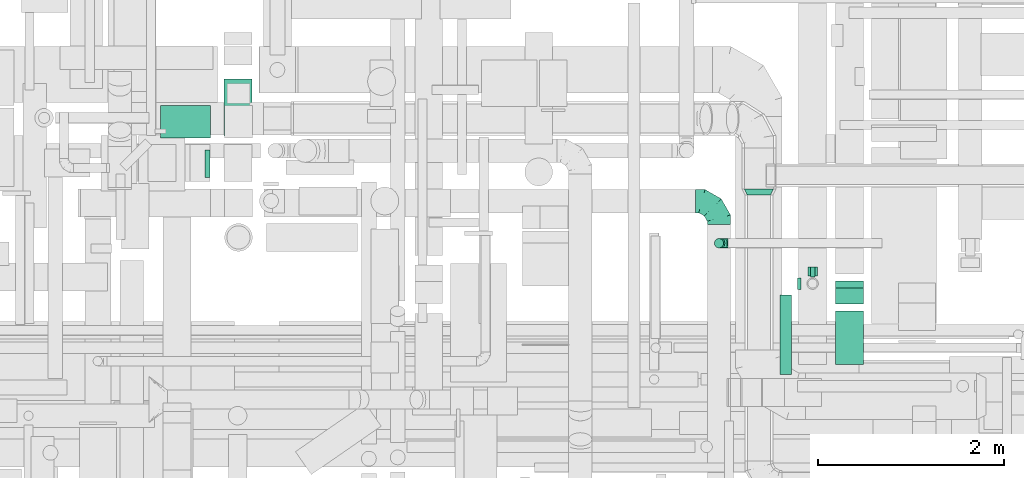
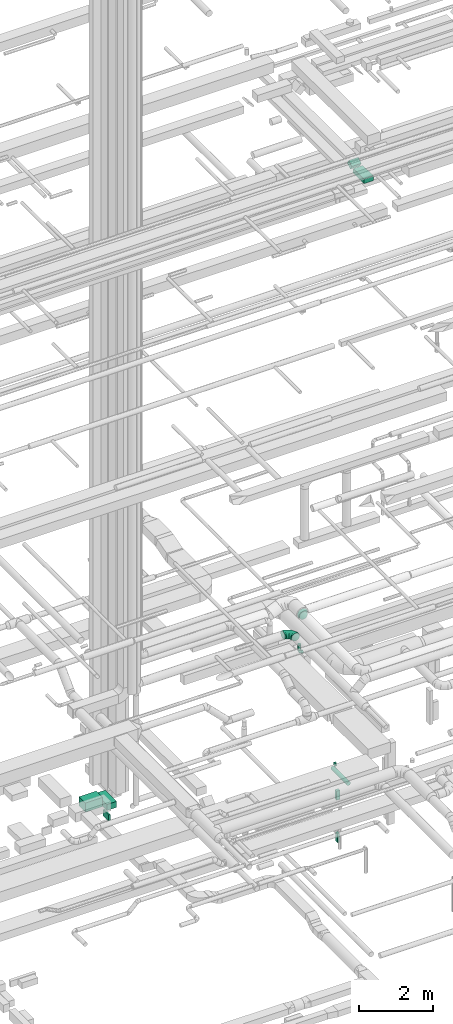
# One storey, part 144 of 337: 10 flow segments, 4 flow fittings.
"""IFC2X3 building model written with IfcOpenShell, lengths in millimetres."""

from ifc_helpers import new_model, entity, si_unit, converted_unit, derived_unit, direction, frame, frame_2d, origin, origin_2d_with_axis, place, context, subcontext, project, spatial, rectangle, circle, extrude, faceted_brep, source, transform, mapped, material, type_object, type_shapes, element, save


model = new_model("IFC2X3")

# Units and contexts
model_context = context("Model", 3, precision=0.01, world=origin(), true_north=direction((6.12303176911189e-17, 1.0)))
body_context = subcontext(model_context, "Body", "Model", "MODEL_VIEW")
ifc_project = project(units=[si_unit("LENGTHUNIT", "METRE", prefix="MILLI"), si_unit("AREAUNIT", "SQUARE_METRE"), si_unit("VOLUMEUNIT", "CUBIC_METRE"), converted_unit("PLANEANGLEUNIT", "DEGREE", entity("IfcRatioMeasure", 0.0174532925199433), si_unit("PLANEANGLEUNIT", "RADIAN"), dimensions=[0, 0, 0, 0, 0, 0, 0]), si_unit("MASSUNIT", "GRAM", prefix="KILO"), derived_unit("MASSDENSITYUNIT", [(si_unit("MASSUNIT", "GRAM", prefix="KILO"), 1), (si_unit("LENGTHUNIT", "METRE"), -3)]), derived_unit("MOMENTOFINERTIAUNIT", [(si_unit("LENGTHUNIT", "METRE"), 4)]), si_unit("TIMEUNIT", "SECOND"), si_unit("FREQUENCYUNIT", "HERTZ"), si_unit("THERMODYNAMICTEMPERATUREUNIT", "DEGREE_CELSIUS"), derived_unit("THERMALTRANSMITTANCEUNIT", [(si_unit("MASSUNIT", "GRAM", prefix="KILO"), 1), (si_unit("THERMODYNAMICTEMPERATUREUNIT", "KELVIN"), -1), (si_unit("TIMEUNIT", "SECOND"), -3)]), derived_unit("VOLUMETRICFLOWRATEUNIT", [(si_unit("LENGTHUNIT", "METRE"), 3), (si_unit("TIMEUNIT", "SECOND"), -1)]), derived_unit("MASSFLOWRATEUNIT", [(si_unit("MASSUNIT", "GRAM", prefix="KILO"), 1), (si_unit("TIMEUNIT", "SECOND"), -1)]), derived_unit("ROTATIONALFREQUENCYUNIT", [(si_unit("TIMEUNIT", "SECOND"), -1)]), si_unit("ELECTRICCURRENTUNIT", "AMPERE"), si_unit("ELECTRICVOLTAGEUNIT", "VOLT"), si_unit("POWERUNIT", "WATT"), si_unit("FORCEUNIT", "NEWTON", prefix="KILO"), si_unit("ILLUMINANCEUNIT", "LUX"), si_unit("LUMINOUSFLUXUNIT", "LUMEN"), si_unit("LUMINOUSINTENSITYUNIT", "CANDELA"), derived_unit("USERDEFINED", [(si_unit("MASSUNIT", "GRAM", prefix="KILO"), -1), (si_unit("LENGTHUNIT", "METRE"), -2), (si_unit("TIMEUNIT", "SECOND"), 3), (si_unit("LUMINOUSFLUXUNIT", "LUMEN"), 1)]), derived_unit("LINEARVELOCITYUNIT", [(si_unit("LENGTHUNIT", "METRE"), 1), (si_unit("TIMEUNIT", "SECOND"), -1)]), si_unit("PRESSUREUNIT", "PASCAL"), derived_unit("USERDEFINED", [(si_unit("LENGTHUNIT", "METRE"), -2), (si_unit("MASSUNIT", "GRAM", prefix="KILO"), 1), (si_unit("TIMEUNIT", "SECOND"), -2)]), derived_unit("LINEARFORCEUNIT", [(si_unit("MASSUNIT", "GRAM", prefix="KILO"), 1), (si_unit("LENGTHUNIT", "METRE"), 1), (si_unit("TIMEUNIT", "SECOND"), -2), (si_unit("LENGTHUNIT", "METRE"), -1)]), derived_unit("PLANARFORCEUNIT", [(si_unit("MASSUNIT", "GRAM", prefix="KILO"), 1), (si_unit("LENGTHUNIT", "METRE"), 1), (si_unit("TIMEUNIT", "SECOND"), -2), (si_unit("LENGTHUNIT", "METRE"), -2)])], contexts=[model_context])

# Site, building, storey
site_placement = place(None, origin())
site = spatial("IfcSite", under=ifc_project, at=site_placement, CompositionType="ELEMENT")
building_placement = place(site_placement, origin())
building = spatial("IfcBuilding", under=site, at=building_placement, CompositionType="ELEMENT")
storey_placement = place(building_placement, origin())
storey = spatial("IfcBuildingStorey", under=building, at=storey_placement, CompositionType="ELEMENT", Elevation=0.0)

# Flow segments
duct_segment_type_1 = type_object("IfcDuctSegmentType", PredefinedType="NOTDEFINED")
flow_segment_1_placement = place(storey_placement, frame((37273.02, 10829.97, -2200.0)))
element("IfcFlowSegment", 1, at=flow_segment_1_placement, inside=storey, type_object=duct_segment_type_1, context=body_context, shape_type="SweptSolid", body=[
    extrude(rectangle(XDim=94.9999971698445, YDim=99.9999999999989, at=origin_2d_with_axis()), frame((50.0, 47.5, 0.0), z_axis=(0.0, 0.0, 1.0), x_axis=(0.0, 1.0, 0.0)), (0.0, 0.0, 1.0), 300.0),
])
flow_segment_2_placement = place(storey_placement, frame((37298.02, 10817.47, -3600.0)))
element("IfcFlowSegment", 2, at=flow_segment_2_placement, inside=storey, type_object=duct_segment_type_1, context=body_context, shape_type="SweptSolid", body=[
    extrude(rectangle(XDim=109.999997169915, YDim=50.0000000000016, at=origin_2d_with_axis()), frame((25.0, 55.0, 0.0), z_axis=(0.0, 0.0, 1.0), x_axis=(0.0, 1.0, 0.0)), (0.0, 0.0, 1.0), 300.0),
])
flow_segment_3_placement = place(storey_placement, frame((30984.29, 12338.04, -1250.0)))
element("IfcFlowSegment", 3, at=flow_segment_3_placement, inside=storey, type_object=duct_segment_type_1, context=body_context, shape_type="SweptSolid", body=[
    extrude(rectangle(XDim=611.836425001198, YDim=300.000000000001, at=origin_2d_with_axis()), frame((150.0, 305.92, 0.0), z_axis=(0.0, 0.0, 1.0), x_axis=(0.0, -1.0, 0.0)), (0.0, 0.0, 1.0), 200.0),
])
flow_segment_4_placement = place(storey_placement, frame((30777.78, 11888.04, -1250.0)))
element("IfcFlowSegment", 4, at=flow_segment_4_placement, inside=storey, type_object=duct_segment_type_1, context=body_context, shape_type="SweptSolid", body=[
    extrude(rectangle(XDim=56.5085500000267, YDim=299.999999999999, at=origin_2d_with_axis()), frame((28.25, 150.0, 0.0), z_axis=(0.0, 0.0, 1.0), x_axis=(-1.0, 0.0, 0.0)), (0.0, 0.0, 1.0), 200.0),
])
flow_segment_5_placement = place(storey_placement, frame((30300.78, 12314.49, -1050.0)))
element("IfcFlowSegment", 5, at=flow_segment_5_placement, inside=storey, type_object=duct_segment_type_1, context=body_context, shape_type="SweptSolid", body=[
    extrude(rectangle(XDim=539.336247854734, YDim=350.000000000001, at=origin_2d_with_axis()), frame((269.67, 175.0, 0.0)), (0.0, 0.0, 1.0), 300.0),
])
flow_segment_6_placement = place(storey_placement, frame((37570.04, 9875.61, 18590.0)))
element("IfcFlowSegment", 6, at=flow_segment_6_placement, inside=storey, type_object=duct_segment_type_1, context=body_context, shape_type="SweptSolid", body=[
    extrude(rectangle(XDim=577.537501664176, YDim=300.000000000001, at=origin_2d_with_axis()), frame((150.0, 288.77, 0.0), z_axis=(0.0, 0.0, 1.0), x_axis=(0.0, 1.0, 0.0)), (0.0, 0.0, 1.0), 150.000000000001),
])
flow_segment_7_placement = place(storey_placement, frame((37570.04, 10528.14, 18630.19)))
element("IfcFlowSegment", 7, at=flow_segment_7_placement, inside=storey, type_object=duct_segment_type_1, context=body_context, shape_type="SweptSolid", body=[
    extrude(rectangle(XDim=150.0, YDim=199.422863405964, at=frame_2d((0.0, 0.0), x_axis=(0.0, 1.0))), frame((0.0, 123.85, 114.81), z_axis=(1.0, 0.0, 0.0), x_axis=(0.0, -0.866025403784387, -0.500000000000089)), (0.0, 0.0, 1.0), 299.999999999997),
])
duct_segment_type_2 = type_object("IfcDuctSegmentType", PredefinedType="NOTDEFINED")
flow_segment_8_placement = place(storey_placement, frame((37158.02, 10683.37, -984.1)))
element("IfcFlowSegment", 8, at=flow_segment_8_placement, inside=storey, type_object=duct_segment_type_2, context=body_context, shape_type="SweptSolid", body=[
    extrude(circle(Radius=62.5, at=origin_2d_with_axis()), frame((0.0, 64.1, 64.1), z_axis=(1.0, 0.0, 0.0), x_axis=(0.0, -1.0, 0.0)), (0.0, 0.0, 1.0), 39.9999999999649),
])
flow_segment_9_placement = place(storey_placement, frame((36262.31, 11130.54, 2900.0)))
element("IfcFlowSegment", 9, at=flow_segment_9_placement, inside=storey, type_object=duct_segment_type_2, context=body_context, shape_type="SweptSolid", body=[
    extrude(circle(Radius=50.0, at=origin_2d_with_axis()), frame((51.6, 51.6, 0.0), z_axis=(0.0, 0.0, 1.0), x_axis=(0.0, -1.0, 0.0)), (0.0, 0.0, 1.0), 134.999999999988),
])
flow_segment_10_placement = place(storey_placement, frame((36968.93, 9768.15, -984.1)))
element("IfcFlowSegment", 10, at=flow_segment_10_placement, inside=storey, type_object=duct_segment_type_2, context=body_context, shape_type="SweptSolid", body=[
    extrude(circle(Radius=62.5, at=origin_2d_with_axis()), frame((64.1, 0.0, 64.1), z_axis=(0.0, 1.0, 0.0), x_axis=(-1.0, 0.0, 0.0)), (0.0, 0.0, 1.0), 854.321482830161),
])

# Flow fittings
ifc_material = material()
duct_fitting_type_1 = type_object("IfcDuctFittingType", PredefinedType="NOTDEFINED", material=ifc_material)
shared_shape_1 = source(origin(), body_context, "Body", "Brep", [
    faceted_brep([(-100.0, 0.0, -50.0), (-100.0, -12.94, -48.3), (-100.0, -25.0, -43.3), (-100.0, -35.36, -35.36), (-100.0, -43.3, -25.0), (-100.0, -48.3, -12.94), (-100.0, -50.0, 0.0), (-100.0, -48.3, 12.94), (-100.0, -43.3, 25.0), (-100.0, -35.36, 35.36), (-100.0, -25.0, 43.3), (-100.0, -12.94, 48.3), (-100.0, 0.0, 50.0), (-100.0, 12.94, 48.3), (-100.0, 25.0, 43.3), (-100.0, 35.36, 35.36), (-100.0, 43.3, 25.0), (-100.0, 48.3, 12.94), (-100.0, 50.0, 0.0), (-100.0, 48.3, -12.94), (-100.0, 43.3, -25.0), (-100.0, 35.36, -35.36), (-100.0, 25.0, -43.3), (-100.0, 12.94, -48.3), (-76.67, 12.94, 48.3), (-79.9, 25.0, 43.3), (-73.21, 0.0, 50.0), (-82.68, 35.36, 35.36), (-86.15, 48.3, 12.94), (-86.6, 50.0, 0.0), (-84.81, 43.3, 25.0), (-84.81, 43.3, -25.0), (-82.68, 35.36, -35.36), (-86.15, 48.3, -12.94), (-76.67, 12.94, -48.3), (-73.21, 0.0, -50.0), (-79.9, 25.0, -43.3), (-69.74, -12.94, -48.3), (-66.51, -25.0, -43.3), (-63.73, -35.36, -35.36), (-61.6, -43.3, -25.0), (-60.26, -48.3, -12.94), (-59.81, -50.0, 0.0), (-60.26, -48.3, 12.94), (-61.6, -43.3, 25.0), (-63.73, -35.36, 35.36), (-66.51, -25.0, 43.3), (-69.74, -12.94, 48.3), (-36.27, 36.27, 48.3), (-45.1, 45.1, 43.3), (-26.79, 26.79, 50.0), (-52.68, 52.68, 35.36), (-58.49, 58.49, 25.0), (-62.15, 62.15, 12.94), (-63.4, 63.4, 0.0), (-62.15, 62.15, -12.94), (-58.49, 58.49, -25.0), (-52.68, 52.68, -35.36), (-36.27, 36.27, -48.3), (-26.79, 26.79, -50.0), (-45.1, 45.1, -43.3), (-17.32, 17.32, -48.3), (-8.49, 8.49, -43.3), (-0.91, 0.91, -35.36), (4.9, -4.9, -25.0), (8.56, -8.56, -12.94), (9.81, -9.81, 0.0), (8.56, -8.56, 12.94), (4.9, -4.9, 25.0), (-0.91, 0.91, 35.36), (-8.49, 8.49, 43.3), (-17.32, 17.32, 48.3), (-12.94, 76.67, 48.3), (-25.0, 79.9, 43.3), (0.0, 73.21, 50.0), (-35.36, 82.68, 35.36), (-43.3, 84.81, 25.0), (-48.3, 86.15, 12.94), (-50.0, 86.6, 0.0), (-48.3, 86.15, -12.94), (-43.3, 84.81, -25.0), (-35.36, 82.68, -35.36), (-12.94, 76.67, -48.3), (0.0, 73.21, -50.0), (-25.0, 79.9, -43.3), (12.94, 69.74, -48.3), (25.0, 66.51, -43.3), (35.36, 63.73, -35.36), (43.3, 61.6, -25.0), (48.3, 60.26, -12.94), (50.0, 59.81, 0.0), (48.3, 60.26, 12.94), (43.3, 61.6, 25.0), (35.36, 63.73, 35.36), (25.0, 66.51, 43.3), (12.94, 69.74, 48.3), (-12.94, 100.0, -48.3), (-25.0, 100.0, -43.3), (-35.36, 100.0, -35.36), (-43.3, 100.0, -25.0), (-48.3, 100.0, -12.94), (-50.0, 100.0, 0.0), (-48.3, 100.0, 12.94), (-43.3, 100.0, 25.0), (-35.36, 100.0, 35.36), (-25.0, 100.0, 43.3), (-12.94, 100.0, 48.3), (0.0, 100.0, 50.0), (12.94, 100.0, 48.3), (25.0, 100.0, 43.3), (35.36, 100.0, 35.36), (43.3, 100.0, 25.0), (48.3, 100.0, 12.94), (50.0, 100.0, 0.0), (48.3, 100.0, -12.94), (43.3, 100.0, -25.0), (35.36, 100.0, -35.36), (25.0, 100.0, -43.3), (12.94, 100.0, -48.3), (0.0, 100.0, -50.0)], [[[0, 1, 2, 3, 4, 5, 6, 7, 8, 9, 10, 11, 12, 13, 14, 15, 16, 17, 18, 19, 20, 21, 22, 23]], [[24, 25, 14, 13]], [[26, 24, 13, 12]], [[14, 25, 27, 15]], [[28, 29, 18, 17]], [[30, 28, 17, 16]], [[15, 27, 30, 16]], [[20, 31, 32, 21]], [[33, 31, 20, 19]], [[18, 29, 33, 19]], [[34, 35, 0, 23]], [[36, 34, 23, 22]], [[32, 36, 22, 21]], [[2, 1, 37, 38]], [[3, 2, 38, 39]], [[0, 35, 37, 1]], [[5, 4, 40, 41]], [[6, 5, 41, 42]], [[3, 39, 40, 4]], [[6, 42, 43, 7]], [[7, 43, 44, 8]], [[8, 44, 45, 9]], [[10, 46, 47, 11]], [[11, 47, 26, 12]], [[10, 9, 45, 46]], [[48, 49, 25, 24]], [[50, 48, 24, 26]], [[27, 25, 49, 51]], [[52, 53, 28, 30]], [[51, 52, 30, 27]], [[29, 28, 53, 54]], [[55, 56, 31, 33]], [[54, 55, 33, 29]], [[57, 32, 31, 56]], [[58, 59, 35, 34]], [[60, 58, 34, 36]], [[57, 60, 36, 32]], [[37, 35, 59, 61]], [[38, 37, 61, 62]], [[39, 38, 62, 63]], [[41, 40, 64, 65]], [[42, 41, 65, 66]], [[63, 64, 40, 39]], [[43, 42, 66, 67]], [[44, 43, 67, 68]], [[68, 69, 45, 44]], [[46, 45, 69, 70]], [[47, 46, 70, 71]], [[26, 47, 71, 50]], [[72, 73, 49, 48]], [[74, 72, 48, 50]], [[51, 49, 73, 75]], [[76, 77, 53, 52]], [[75, 76, 52, 51]], [[54, 53, 77, 78]], [[79, 80, 56, 55]], [[78, 79, 55, 54]], [[81, 57, 56, 80]], [[82, 83, 59, 58]], [[84, 82, 58, 60]], [[81, 84, 60, 57]], [[61, 59, 83, 85]], [[62, 61, 85, 86]], [[63, 62, 86, 87]], [[65, 64, 88, 89]], [[66, 65, 89, 90]], [[87, 88, 64, 63]], [[67, 66, 90, 91]], [[68, 67, 91, 92]], [[92, 93, 69, 68]], [[70, 69, 93, 94]], [[71, 70, 94, 95]], [[50, 71, 95, 74]], [[96, 97, 98, 99, 100, 101, 102, 103, 104, 105, 106, 107, 108, 109, 110, 111, 112, 113, 114, 115, 116, 117, 118, 119]], [[72, 74, 107, 106]], [[73, 72, 106, 105]], [[75, 73, 105, 104]], [[77, 76, 103, 102]], [[78, 77, 102, 101]], [[75, 104, 103, 76]], [[78, 101, 100, 79]], [[79, 100, 99, 80]], [[80, 99, 98, 81]], [[96, 119, 83, 82]], [[97, 96, 82, 84]], [[84, 81, 98, 97]], [[83, 119, 118, 85]], [[85, 118, 117, 86]], [[86, 117, 116, 87]], [[88, 115, 114, 89]], [[89, 114, 113, 90]], [[87, 116, 115, 88]], [[91, 90, 113, 112]], [[92, 91, 112, 111]], [[93, 92, 111, 110]], [[95, 94, 109, 108]], [[74, 95, 108, 107]], [[110, 109, 94, 93]]]),
])
type_shapes(duct_fitting_type_1, [shared_shape_1])
flow_fitting_1_placement = place(storey_placement, frame((36313.9, 11182.13, 2800.0), z_axis=(0.0, -1.0, 0.0), x_axis=(0.0, 0.0, -1.0)))
element("IfcFlowFitting", 11, at=flow_fitting_1_placement, inside=storey, type_object=duct_fitting_type_1, material=ifc_material, context=body_context, shape_type="MappedRepresentation", body=[
    mapped(shared_shape_1, transform((0.0, 0.0, 0.0), scale=1.0)),
])
duct_fitting_type_2 = type_object("IfcDuctFittingType", PredefinedType="NOTDEFINED", material=ifc_material)
shared_shape_2 = source(origin(), body_context, "Body", "Brep", [
    faceted_brep([(-250.0, 0.0, -125.0), (-250.0, -32.35, -120.74), (-250.0, -62.5, -108.25), (-250.0, -88.39, -88.39), (-250.0, -108.25, -62.5), (-250.0, -120.74, -32.35), (-250.0, -125.0, 0.0), (-250.0, -120.74, 32.35), (-250.0, -108.25, 62.5), (-250.0, -88.39, 88.39), (-250.0, -62.5, 108.25), (-250.0, -32.35, 120.74), (-250.0, 0.0, 125.0), (-250.0, 32.35, 120.74), (-250.0, 62.5, 108.25), (-250.0, 88.39, 88.39), (-250.0, 108.25, 62.5), (-250.0, 120.74, 32.35), (-250.0, 125.0, 0.0), (-250.0, 120.74, -32.35), (-250.0, 108.25, -62.5), (-250.0, 88.39, -88.39), (-250.0, 62.5, -108.25), (-250.0, 32.35, -120.74), (-191.68, 32.35, 120.74), (-199.76, 62.5, 108.25), (-183.01, 0.0, 125.0), (-206.7, 88.39, 88.39), (-215.37, 120.74, 32.35), (-216.51, 125.0, 0.0), (-212.02, 108.25, 62.5), (-212.02, 108.25, -62.5), (-206.7, 88.39, -88.39), (-215.37, 120.74, -32.35), (-191.68, 32.35, -120.74), (-183.01, 0.0, -125.0), (-199.76, 62.5, -108.25), (-174.34, -32.35, -120.74), (-166.27, -62.5, -108.25), (-159.33, -88.39, -88.39), (-154.01, -108.25, -62.5), (-150.66, -120.74, -32.35), (-149.52, -125.0, 0.0), (-150.66, -120.74, 32.35), (-154.01, -108.25, 62.5), (-159.33, -88.39, 88.39), (-166.27, -62.5, 108.25), (-174.34, -32.35, 120.74), (-90.67, 90.67, 120.74), (-112.74, 112.74, 108.25), (-66.99, 66.99, 125.0), (-131.69, 131.69, 88.39), (-146.23, 146.23, 62.5), (-155.38, 155.38, 32.35), (-158.49, 158.49, 0.0), (-155.38, 155.38, -32.35), (-146.23, 146.23, -62.5), (-131.69, 131.69, -88.39), (-90.67, 90.67, -120.74), (-66.99, 66.99, -125.0), (-112.74, 112.74, -108.25), (-43.3, 43.3, -120.74), (-21.23, 21.23, -108.25), (-2.28, 2.28, -88.39), (12.26, -12.26, -62.5), (21.4, -21.4, -32.35), (24.52, -24.52, 0.0), (21.4, -21.4, 32.35), (12.26, -12.26, 62.5), (-2.28, 2.28, 88.39), (-21.23, 21.23, 108.25), (-43.3, 43.3, 120.74), (-32.35, 191.68, 120.74), (-62.5, 199.76, 108.25), (0.0, 183.01, 125.0), (-88.39, 206.7, 88.39), (-108.25, 212.02, 62.5), (-120.74, 215.37, 32.35), (-125.0, 216.51, 0.0), (-120.74, 215.37, -32.35), (-108.25, 212.02, -62.5), (-88.39, 206.7, -88.39), (-32.35, 191.68, -120.74), (0.0, 183.01, -125.0), (-62.5, 199.76, -108.25), (32.35, 174.34, -120.74), (62.5, 166.27, -108.25), (88.39, 159.33, -88.39), (108.25, 154.01, -62.5), (120.74, 150.66, -32.35), (125.0, 149.52, 0.0), (120.74, 150.66, 32.35), (108.25, 154.01, 62.5), (88.39, 159.33, 88.39), (62.5, 166.27, 108.25), (32.35, 174.34, 120.74), (-32.35, 250.0, -120.74), (-62.5, 250.0, -108.25), (-88.39, 250.0, -88.39), (-108.25, 250.0, -62.5), (-120.74, 250.0, -32.35), (-125.0, 250.0, 0.0), (-120.74, 250.0, 32.35), (-108.25, 250.0, 62.5), (-88.39, 250.0, 88.39), (-62.5, 250.0, 108.25), (-32.35, 250.0, 120.74), (0.0, 250.0, 125.0), (32.35, 250.0, 120.74), (62.5, 250.0, 108.25), (88.39, 250.0, 88.39), (108.25, 250.0, 62.5), (120.74, 250.0, 32.35), (125.0, 250.0, 0.0), (120.74, 250.0, -32.35), (108.25, 250.0, -62.5), (88.39, 250.0, -88.39), (62.5, 250.0, -108.25), (32.35, 250.0, -120.74), (0.0, 250.0, -125.0)], [[[0, 1, 2, 3, 4, 5, 6, 7, 8, 9, 10, 11, 12, 13, 14, 15, 16, 17, 18, 19, 20, 21, 22, 23]], [[24, 25, 14, 13]], [[26, 24, 13, 12]], [[14, 25, 27, 15]], [[28, 29, 18, 17]], [[30, 28, 17, 16]], [[15, 27, 30, 16]], [[20, 31, 32, 21]], [[33, 31, 20, 19]], [[18, 29, 33, 19]], [[34, 35, 0, 23]], [[36, 34, 23, 22]], [[21, 32, 36, 22]], [[1, 0, 35, 37]], [[2, 1, 37, 38]], [[38, 39, 3, 2]], [[5, 4, 40, 41]], [[6, 5, 41, 42]], [[39, 40, 4, 3]], [[6, 42, 43, 7]], [[7, 43, 44, 8]], [[8, 44, 45, 9]], [[9, 45, 46, 10]], [[10, 46, 47, 11]], [[26, 12, 11, 47]], [[48, 49, 25, 24]], [[50, 48, 24, 26]], [[27, 25, 49, 51]], [[52, 53, 28, 30]], [[51, 52, 30, 27]], [[29, 28, 53, 54]], [[55, 56, 31, 33]], [[54, 55, 33, 29]], [[32, 31, 56, 57]], [[58, 59, 35, 34]], [[60, 58, 34, 36]], [[57, 60, 36, 32]], [[37, 35, 59, 61]], [[38, 37, 61, 62]], [[39, 38, 62, 63]], [[41, 40, 64, 65]], [[42, 41, 65, 66]], [[63, 64, 40, 39]], [[43, 42, 66, 67]], [[44, 43, 67, 68]], [[68, 69, 45, 44]], [[46, 45, 69, 70]], [[47, 46, 70, 71]], [[26, 47, 71, 50]], [[72, 73, 49, 48]], [[74, 72, 48, 50]], [[51, 49, 73, 75]], [[76, 77, 53, 52]], [[75, 76, 52, 51]], [[54, 53, 77, 78]], [[79, 80, 56, 55]], [[78, 79, 55, 54]], [[57, 56, 80, 81]], [[82, 83, 59, 58]], [[84, 82, 58, 60]], [[81, 84, 60, 57]], [[61, 59, 83, 85]], [[62, 61, 85, 86]], [[63, 62, 86, 87]], [[65, 64, 88, 89]], [[66, 65, 89, 90]], [[87, 88, 64, 63]], [[67, 66, 90, 91]], [[68, 67, 91, 92]], [[92, 93, 69, 68]], [[70, 69, 93, 94]], [[71, 70, 94, 95]], [[50, 71, 95, 74]], [[96, 97, 98, 99, 100, 101, 102, 103, 104, 105, 106, 107, 108, 109, 110, 111, 112, 113, 114, 115, 116, 117, 118, 119]], [[72, 74, 107, 106]], [[73, 72, 106, 105]], [[75, 73, 105, 104]], [[77, 76, 103, 102]], [[78, 77, 102, 101]], [[75, 104, 103, 76]], [[78, 101, 100, 79]], [[79, 100, 99, 80]], [[80, 99, 98, 81]], [[84, 97, 96, 82]], [[82, 96, 119, 83]], [[84, 81, 98, 97]], [[83, 119, 118, 85]], [[85, 118, 117, 86]], [[116, 87, 86, 117]], [[88, 115, 114, 89]], [[89, 114, 113, 90]], [[115, 88, 87, 116]], [[91, 90, 113, 112]], [[92, 91, 112, 111]], [[111, 110, 93, 92]], [[95, 94, 109, 108]], [[74, 95, 108, 107]], [[110, 109, 94, 93]]]),
])
type_shapes(duct_fitting_type_2, [shared_shape_2])
flow_fitting_2_placement = place(storey_placement, frame((36313.9, 11635.42, 3180.0), z_axis=(0.0, 0.0, 1.0), x_axis=(0.0, 1.0, 0.0)))
element("IfcFlowFitting", 12, at=flow_fitting_2_placement, inside=storey, type_object=duct_fitting_type_2, material=ifc_material, context=body_context, shape_type="MappedRepresentation", body=[
    mapped(shared_shape_2, transform((0.0, 0.0, 0.0), scale=1.0)),
])
duct_fitting_type_3 = type_object("IfcDuctFittingType", PredefinedType="NOTDEFINED", material=ifc_material)
shared_shape_3 = source(origin(), body_context, "Body", "Brep", [
    faceted_brep([(20.0, 12.94, -48.3), (20.0, 25.0, -43.3), (20.0, 35.36, -35.36), (20.0, 43.3, -25.0), (20.0, 48.3, -12.94), (20.0, 50.0, 0.0), (20.0, 48.3, 12.94), (20.0, 43.3, 25.0), (20.0, 35.36, 35.36), (20.0, 25.0, 43.3), (20.0, 12.94, 48.3), (20.0, 0.0, 50.0), (20.0, -12.94, 48.3), (20.0, -25.0, 43.3), (20.0, -35.36, 35.36), (20.0, -43.3, 25.0), (20.0, -48.3, 12.94), (20.0, -50.0, 0.0), (20.0, -48.3, -12.94), (20.0, -43.3, -25.0), (20.0, -35.36, -35.36), (20.0, -25.0, -43.3), (20.0, -12.94, -48.3), (20.0, 0.0, -50.0), (0.0, 0.0, 50.0), (0.0, 12.94, 48.3), (-16.53, 12.94, 48.3), (-16.53, 0.0, 50.0), (0.0, 25.0, 43.3), (-16.53, 25.0, 43.3), (0.0, 35.36, 35.36), (-16.53, 35.36, 35.36), (0.0, 43.3, 25.0), (0.0, 48.3, 12.94), (-16.53, 48.3, 12.94), (-16.53, 43.3, 25.0), (0.0, 50.0, 0.0), (-16.53, 50.0, 0.0), (0.0, 48.3, -12.94), (-16.53, 48.3, -12.94), (0.0, 43.3, -25.0), (-16.53, 43.3, -25.0), (0.0, 35.36, -35.36), (-16.53, 35.36, -35.36), (0.0, 25.0, -43.3), (0.0, 12.94, -48.3), (-16.53, 12.94, -48.3), (-16.53, 25.0, -43.3), (0.0, 0.0, -50.0), (-16.53, 0.0, -50.0), (0.0, -12.94, -48.3), (-16.53, -12.94, -48.3), (0.0, -25.0, -43.3), (-16.53, -25.0, -43.3), (0.0, -35.36, -35.36), (-16.53, -35.36, -35.36), (0.0, -43.3, -25.0), (0.0, -48.3, -12.94), (-16.53, -48.3, -12.94), (-16.53, -43.3, -25.0), (0.0, -50.0, 0.0), (-16.53, -50.0, 0.0), (0.0, -48.3, 12.94), (-16.53, -48.3, 12.94), (0.0, -43.3, 25.0), (-16.53, -43.3, 25.0), (0.0, -35.36, 35.36), (-16.53, -35.36, 35.36), (0.0, -25.0, 43.3), (0.0, -12.94, 48.3), (-16.53, -12.94, 48.3), (-16.53, -25.0, 43.3)], [[[0, 1, 2, 3, 4, 5, 6, 7, 8, 9, 10, 11, 12, 13, 14, 15, 16, 17, 18, 19, 20, 21, 22, 23]], [[24, 11, 10, 25, 26, 27]], [[25, 10, 9, 28, 29, 26]], [[28, 9, 8, 30, 31, 29]], [[32, 7, 6, 33, 34, 35]], [[33, 6, 5, 36, 37, 34]], [[30, 8, 7, 32, 35, 31]], [[36, 5, 4, 38, 39, 37]], [[38, 4, 3, 40, 41, 39]], [[40, 3, 2, 42, 43, 41]], [[44, 1, 0, 45, 46, 47]], [[45, 0, 23, 48, 49, 46]], [[42, 2, 1, 44, 47, 43]], [[48, 23, 22, 50, 51, 49]], [[50, 22, 21, 52, 53, 51]], [[52, 21, 20, 54, 55, 53]], [[56, 19, 18, 57, 58, 59]], [[57, 18, 17, 60, 61, 58]], [[54, 20, 19, 56, 59, 55]], [[60, 17, 16, 62, 63, 61]], [[62, 16, 15, 64, 65, 63]], [[64, 15, 14, 66, 67, 65]], [[68, 13, 12, 69, 70, 71]], [[69, 12, 11, 24, 27, 70]], [[66, 14, 13, 68, 71, 67]], [[49, 51, 53, 55, 59, 58, 61, 63, 65, 67, 71, 70, 27, 26, 29, 31, 35, 34, 37, 39, 41, 43, 47, 46]]]),
])
type_shapes(duct_fitting_type_3, [shared_shape_3])
flow_fitting_3_placement = place(storey_placement, frame((36313.9, 11182.13, 3055.0), z_axis=(1.0, 0.0, 0.0), x_axis=(0.0, 0.0, -1.0)))
element("IfcFlowFitting", 13, at=flow_fitting_3_placement, inside=storey, type_object=duct_fitting_type_3, material=ifc_material, context=body_context, shape_type="MappedRepresentation", body=[
    mapped(shared_shape_3, transform((0.0, 0.0, 0.0), scale=1.0)),
])
duct_fitting_type_4 = type_object("IfcDuctFittingType", PredefinedType="NOTDEFINED", material=ifc_material)
shared_shape_4 = source(origin(), body_context, "Body", "Brep", [
    faceted_brep([(65.0, -78.75, -103.9), (65.0, -40.76, -119.63), (65.0, 0.0, -125.0), (65.0, 40.76, -119.63), (65.0, 78.75, -103.9), (65.0, 111.37, -78.87), (65.0, 136.4, -46.25), (65.0, 152.13, -8.26), (65.0, 157.5, 32.5), (65.0, 152.13, 73.26), (65.0, 136.4, 111.25), (65.0, 111.37, 143.87), (65.0, 78.75, 168.9), (65.0, 40.76, 184.63), (65.0, 0.0, 190.0), (65.0, -40.76, 184.63), (65.0, -78.75, 168.9), (65.0, -111.37, 143.87), (65.0, -136.4, 111.25), (65.0, -152.13, 73.26), (65.0, -157.5, 32.5), (65.0, -152.13, -8.26), (65.0, -136.4, -46.25), (65.0, -111.37, -78.87), (0.0, 118.88, 38.63), (0.0, 125.0, 0.0), (0.0, 118.88, -38.63), (0.0, 101.13, -73.47), (0.0, 87.3, -87.3), (0.0, 73.47, -101.13), (0.0, 38.63, -118.88), (0.0, 0.0, -125.0), (0.0, -38.63, -118.88), (0.0, -73.47, -101.13), (0.0, -87.3, -87.3), (0.0, -101.13, -73.47), (0.0, -118.88, -38.63), (0.0, -125.0, 0.0), (0.0, -118.88, 38.63), (0.0, -101.13, 73.47), (0.0, -87.3, 87.3), (0.0, -73.47, 101.13), (0.0, -38.63, 118.88), (0.0, 0.0, 125.0), (0.0, 38.63, 118.88), (0.0, 73.47, 101.13), (0.0, 87.3, 87.3), (0.0, 101.13, 73.47), (27.61, 136.24, 40.37), (39.27, 144.63, 19.63), (34.87, 131.59, 71.94), (33.33, 117.38, 95.98), (39.27, 0.0, 164.27), (27.61, 26.57, 150.04), (33.33, 79.32, 134.04), (32.96, 100.04, 116.52), (34.87, 54.51, 149.03), (35.99, 142.99, 17.99), (27.61, -26.57, 150.04), (34.87, -54.51, 149.03), (33.33, -79.32, 134.04), (27.61, -136.24, 40.37), (35.99, -142.99, 17.99), (39.27, -144.63, 19.63), (33.33, -117.38, 95.98), (32.96, -100.04, 116.52), (34.87, -131.59, 71.94), (35.99, 0.0, -125.0), (27.42, -26.95, -122.36), (27.42, -136.07, -13.24), (34.87, -131.59, -37.07), (33.33, -117.38, -62.65), (34.87, -54.51, -114.16), (33.33, -79.32, -100.71), (32.96, -100.04, -83.56), (27.42, 136.07, -13.24), (27.42, 26.95, -122.36), (34.87, 54.51, -114.16), (33.33, 79.32, -100.71), (34.87, 131.59, -37.07), (33.33, 117.38, -62.65), (32.96, 100.04, -83.56)], [[[0, 1, 2, 3, 4, 5, 6, 7, 8, 9, 10, 11, 12, 13, 14, 15, 16, 17, 18, 19, 20, 21, 22, 23]], [[24, 25, 26, 27, 28, 29, 30, 31, 32, 33, 34, 35, 36, 37, 38, 39, 40, 41, 42, 43, 44, 45, 46, 47]], [[48, 9, 49]], [[47, 50, 24]], [[51, 50, 47]], [[48, 24, 50]], [[9, 8, 49]], [[24, 48, 25]], [[10, 9, 50]], [[52, 53, 43]], [[51, 10, 50]], [[45, 54, 55]], [[45, 44, 56]], [[48, 49, 57, 25]], [[13, 53, 52]], [[52, 14, 13]], [[9, 48, 50]], [[45, 56, 54]], [[53, 56, 44]], [[12, 56, 13]], [[13, 56, 53]], [[56, 12, 54]], [[43, 53, 44]], [[11, 55, 54]], [[12, 11, 54]], [[11, 10, 51]], [[47, 46, 45, 55]], [[55, 11, 51]], [[47, 55, 51]], [[58, 15, 52]], [[41, 59, 42]], [[60, 59, 41]], [[58, 42, 59]], [[15, 14, 52]], [[42, 58, 43]], [[16, 15, 59]], [[61, 37, 62, 63]], [[60, 16, 59]], [[39, 64, 65]], [[39, 38, 66]], [[43, 58, 52]], [[19, 61, 63]], [[63, 20, 19]], [[15, 58, 59]], [[39, 66, 64]], [[61, 66, 38]], [[18, 66, 19]], [[19, 66, 61]], [[66, 18, 64]], [[37, 61, 38]], [[17, 65, 64]], [[18, 17, 64]], [[17, 16, 60]], [[41, 40, 39, 65]], [[65, 17, 60]], [[41, 65, 60]], [[67, 2, 68, 31]], [[21, 69, 70]], [[71, 70, 35]], [[69, 36, 70]], [[69, 20, 63, 62, 37]], [[36, 69, 37]], [[22, 21, 70]], [[21, 20, 69]], [[71, 22, 70]], [[23, 22, 71]], [[33, 32, 72]], [[33, 73, 74]], [[35, 34, 33, 74]], [[2, 1, 68]], [[35, 70, 36]], [[33, 72, 73]], [[68, 72, 32]], [[0, 72, 1]], [[1, 72, 68]], [[0, 23, 73]], [[23, 74, 73]], [[74, 23, 71]], [[72, 0, 73]], [[31, 68, 32]], [[35, 74, 71]], [[57, 49, 8, 75, 25]], [[3, 76, 77]], [[78, 77, 29]], [[76, 30, 77]], [[2, 67, 31, 76]], [[30, 76, 31]], [[4, 3, 77]], [[3, 2, 76]], [[78, 4, 77]], [[5, 4, 78]], [[27, 26, 79]], [[27, 80, 81]], [[29, 28, 27, 81]], [[8, 7, 75]], [[29, 77, 30]], [[27, 79, 80]], [[75, 79, 26]], [[6, 79, 7]], [[7, 79, 75]], [[6, 5, 80]], [[5, 81, 80]], [[81, 5, 78]], [[79, 6, 80]], [[25, 75, 26]], [[29, 81, 78]]]),
])
type_shapes(duct_fitting_type_4, [shared_shape_4])
flow_fitting_4_placement = place(storey_placement, frame((36744.56, 11699.99, 3550.0), z_axis=(0.0, 0.0, 1.0), x_axis=(0.0, 1.0, 0.0)))
element("IfcFlowFitting", 14, at=flow_fitting_4_placement, inside=storey, type_object=duct_fitting_type_4, material=ifc_material, context=body_context, shape_type="MappedRepresentation", body=[
    mapped(shared_shape_4, transform((0.0, 0.0, 0.0), scale=1.0)),
])

save(model, "model.ifc")
